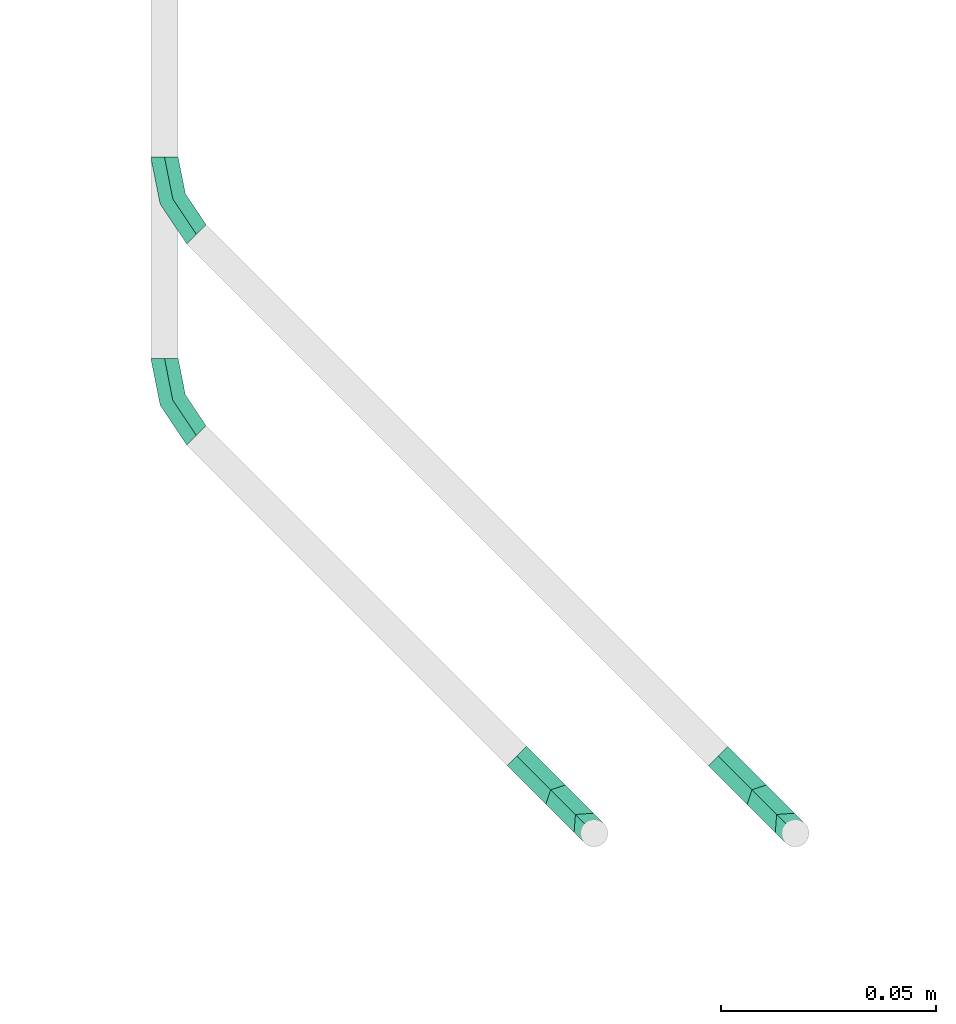
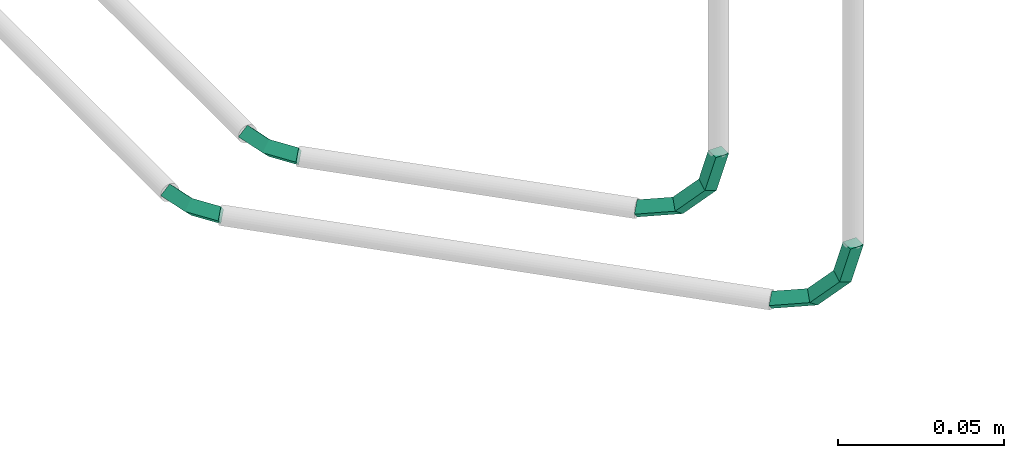
# One storey, part 42 of 45: 4 flow fittings.
"""IFC2X3 building model written with IfcOpenShell, lengths in millimetres."""

from ifc_helpers import new_model, entity, si_unit, converted_unit, derived_unit, direction, frame, origin, place, context, subcontext, project, spatial, faceted_brep, material, type_object, element, save


model = new_model("IFC2X3")

# Units and contexts
model_context = context("Model", 3, precision=0.01, world=origin(), true_north=direction((6.12303176911189e-17, 1.0)))
body_context = subcontext(model_context, "Body", "Model", "MODEL_VIEW")
ifc_project = project(units=[si_unit("LENGTHUNIT", "METRE", prefix="MILLI"), si_unit("AREAUNIT", "SQUARE_METRE"), si_unit("VOLUMEUNIT", "CUBIC_METRE"), converted_unit("PLANEANGLEUNIT", "DEGREE", entity("IfcRatioMeasure", 0.0174532925199433), si_unit("PLANEANGLEUNIT", "RADIAN"), dimensions=[0, 0, 0, 0, 0, 0, 0]), si_unit("MASSUNIT", "GRAM", prefix="KILO"), derived_unit("MASSDENSITYUNIT", [(si_unit("MASSUNIT", "GRAM", prefix="KILO"), 1), (si_unit("LENGTHUNIT", "METRE"), -3)]), derived_unit("MOMENTOFINERTIAUNIT", [(si_unit("LENGTHUNIT", "METRE"), 4)]), si_unit("TIMEUNIT", "SECOND"), si_unit("FREQUENCYUNIT", "HERTZ"), si_unit("THERMODYNAMICTEMPERATUREUNIT", "DEGREE_CELSIUS"), derived_unit("THERMALTRANSMITTANCEUNIT", [(si_unit("MASSUNIT", "GRAM", prefix="KILO"), 1), (si_unit("THERMODYNAMICTEMPERATUREUNIT", "KELVIN"), -1), (si_unit("TIMEUNIT", "SECOND"), -3)]), derived_unit("VOLUMETRICFLOWRATEUNIT", [(si_unit("LENGTHUNIT", "METRE"), 3), (si_unit("TIMEUNIT", "SECOND"), -1)]), derived_unit("MASSFLOWRATEUNIT", [(si_unit("MASSUNIT", "GRAM", prefix="KILO"), 1), (si_unit("TIMEUNIT", "SECOND"), -1)]), derived_unit("ROTATIONALFREQUENCYUNIT", [(si_unit("TIMEUNIT", "SECOND"), -1)]), si_unit("ELECTRICCURRENTUNIT", "AMPERE"), si_unit("ELECTRICVOLTAGEUNIT", "VOLT"), si_unit("POWERUNIT", "WATT"), si_unit("FORCEUNIT", "NEWTON", prefix="KILO"), si_unit("ILLUMINANCEUNIT", "LUX"), si_unit("LUMINOUSFLUXUNIT", "LUMEN"), si_unit("LUMINOUSINTENSITYUNIT", "CANDELA"), derived_unit("USERDEFINED", [(si_unit("MASSUNIT", "GRAM", prefix="KILO"), -1), (si_unit("LENGTHUNIT", "METRE"), -2), (si_unit("TIMEUNIT", "SECOND"), 3), (si_unit("LUMINOUSFLUXUNIT", "LUMEN"), 1)]), derived_unit("LINEARVELOCITYUNIT", [(si_unit("LENGTHUNIT", "METRE"), 1), (si_unit("TIMEUNIT", "SECOND"), -1)]), si_unit("PRESSUREUNIT", "PASCAL"), derived_unit("USERDEFINED", [(si_unit("LENGTHUNIT", "METRE"), -2), (si_unit("MASSUNIT", "GRAM", prefix="KILO"), 1), (si_unit("TIMEUNIT", "SECOND"), -2)]), derived_unit("LINEARFORCEUNIT", [(si_unit("MASSUNIT", "GRAM", prefix="KILO"), 1), (si_unit("LENGTHUNIT", "METRE"), 1), (si_unit("TIMEUNIT", "SECOND"), -2), (si_unit("LENGTHUNIT", "METRE"), -1)]), derived_unit("PLANARFORCEUNIT", [(si_unit("MASSUNIT", "GRAM", prefix="KILO"), 1), (si_unit("LENGTHUNIT", "METRE"), 1), (si_unit("TIMEUNIT", "SECOND"), -2), (si_unit("LENGTHUNIT", "METRE"), -2)])], contexts=[model_context])

# Site, building, storey
site_placement = place(None, frame((-24836.06, 8968.75, 0.0)))
site = spatial("IfcSite", under=ifc_project, at=site_placement, CompositionType="ELEMENT")
building_placement = place(site_placement, origin())
building = spatial("IfcBuilding", under=site, at=building_placement, CompositionType="ELEMENT")
storey_placement = place(building_placement, frame((0.0, 0.0, -4200.0)))
storey = spatial("IfcBuildingStorey", under=building, at=storey_placement, CompositionType="ELEMENT", Elevation=-4200.0)

# Flow fittings
ifc_material = material()
pipe_fitting_type_1 = type_object("IfcPipeFittingType", PredefinedType="NOTDEFINED", material=ifc_material)
for number, where in (
    (1, (87922.87, -6741.0, 2146.82)),
    (2, (87876.04, -6741.0, 2196.82)),
):
    element("IfcFlowFitting", number, at=place(storey_placement, frame(where)), inside=storey, type_object=pipe_fitting_type_1, context=body_context, shape_type="Brep", body=[
        faceted_brep([(22.45, 0.0, 28.57), (19.74, 2.71, 14.29), (20.04, 6.9, 15.88), (22.45, 4.49, 28.57), (15.86, 6.6, 17.46), (17.96, 4.49, 28.57), (15.55, 2.41, 15.88), (17.96, 0.0, 28.57), (12.35, 10.1, 3.83), (13.47, 13.47, 6.58), (10.1, 12.35, 9.33), (8.98, 8.98, 6.58), (2.25, 20.21, 0.0), (4.49, 22.45, 3.17), (2.25, 20.21, 6.35), (0.0, 17.96, 3.17)], [[[0, 1, 2, 3]], [[3, 2, 4, 5]], [[5, 4, 6, 7]], [[7, 6, 1, 0]], [[1, 8, 9, 2]], [[2, 9, 10, 4]], [[4, 10, 11, 6]], [[6, 11, 8, 1]], [[8, 12, 13, 9]], [[9, 13, 14, 10]], [[10, 14, 15, 11]], [[11, 15, 12, 8]], [[7, 0, 3, 5]], [[12, 15, 14, 13]]]),
    ])
pipe_fitting_type_2 = type_object("IfcPipeFittingType", PredefinedType="NOTDEFINED", material=ifc_material)
for number, where in (
    (3, (87793.07, -6601.61, 2146.82)),
    (4, (87793.07, -6648.44, 2196.82)),
):
    element("IfcFlowFitting", number, at=place(storey_placement, frame(where)), inside=storey, type_object=pipe_fitting_type_2, context=body_context, shape_type="Brep", body=[
        faceted_brep([(8.37, 0.0, 3.17), (2.18, 9.27, 3.17), (5.11, 10.49, 0.0), (10.61, 2.25, 0.0), (8.04, 11.7, 3.17), (12.86, 4.49, 3.17), (5.11, 10.49, 6.35), (10.61, 2.25, 6.35), (0.0, 20.21, 3.17), (3.18, 20.21, 0.0), (6.35, 20.21, 3.17), (3.18, 20.21, 6.35)], [[[0, 1, 2, 3]], [[3, 2, 4, 5]], [[5, 4, 6, 7]], [[7, 6, 1, 0]], [[1, 8, 9, 2]], [[2, 9, 10, 4]], [[4, 10, 11, 6]], [[6, 11, 8, 1]], [[7, 0, 3, 5]], [[8, 11, 10, 9]]]),
    ])

save(model, "model.ifc")
